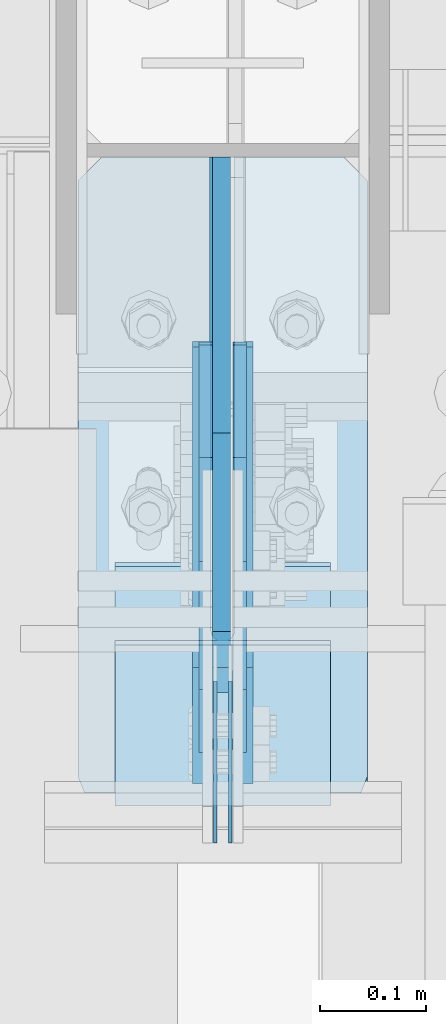
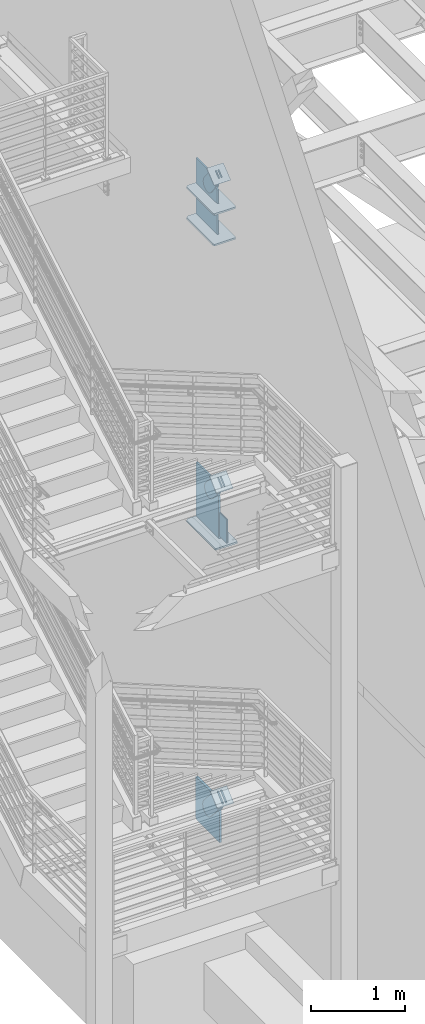
# One storey, part 1058 of 1179: 17 plates, 11 elements without a shape of their own.
"""IFC2X3 building model written with IfcOpenShell, lengths in millimetres."""

from ifc_helpers import new_model, si_unit, frame, origin_with_axes, place, context, subcontext, project, spatial, faceted_brep, material, type_object, element, aggregate, save


model = new_model("IFC2X3")

# Units and contexts
model_context = context("Model", 3, precision=1e-05, world=origin_with_axes())
body_context = subcontext(model_context, "Body", "Model", "MODEL_VIEW")
ifc_project = project(units=[si_unit("LENGTHUNIT", "METRE", prefix="MILLI"), si_unit("AREAUNIT", "SQUARE_METRE"), si_unit("VOLUMEUNIT", "CUBIC_METRE"), si_unit("MASSUNIT", "GRAM", prefix="KILO"), si_unit("TIMEUNIT", "SECOND"), si_unit("PLANEANGLEUNIT", "RADIAN"), si_unit("SOLIDANGLEUNIT", "STERADIAN"), si_unit("THERMODYNAMICTEMPERATUREUNIT", "DEGREE_CELSIUS"), si_unit("LUMINOUSINTENSITYUNIT", "LUMEN")], contexts=[model_context])

# Site, building, storey
site_placement = place(None, origin_with_axes())
site = spatial("IfcSite", under=ifc_project, at=site_placement, CompositionType="ELEMENT")
building_placement = place(site_placement, origin_with_axes())
building = spatial("IfcBuilding", under=site, at=building_placement, Name="Undefined", CompositionType="ELEMENT")
storey_placement = place(building_placement, origin_with_axes())
storey = spatial("IfcBuildingStorey", under=building, at=storey_placement, Name="Undefined", CompositionType="ELEMENT", Elevation=0.0)

# Assembly, plates
assembly_1_placement = place(storey_placement, origin_with_axes())
assembly_1 = element("IfcElementAssembly", 1, at=assembly_1_placement, inside=storey, Name="COLUMN", AssemblyPlace="NOTDEFINED", PredefinedType="RIGID_FRAME")
ifc_material_1 = material(Name="STEEL/A572-GR.50")
plate_type_1 = type_object("IfcPlateType", PredefinedType="NOTDEFINED")
plate_1_placement = place(assembly_1_placement, frame((295.274993912948, 33785.7907939296, 7605.7125), z_axis=(0.0, 1.0, 0.0), x_axis=(1.0, 0.0, 0.0)))
plate_1 = element("IfcPlate", 2, at=plate_1_placement, type_object=plate_type_1, material=ifc_material_1, Name="PLATE", context=body_context, shape_type="Brep", body=[
    faceted_brep([(125.412506087054, -11.1125000000002, 599.459206069892), (125.412487792968, -11.1125000000002, 153.987500190735), (125.412487792968, 11.1125000000002, 153.987500190735), (125.412506087054, 11.1125000000002, 599.459206069892), (126.258376502454, -11.1125000000002, 149.734930475586), (126.258376502454, 11.1125000000002, 149.734930475586), (128.667263742896, -11.1125000000002, 146.12977594993), (128.667263742896, 11.1125000000002, 146.12977594993), (132.272418268556, -11.1125000000002, 143.720888709488), (132.272418268556, 11.1125000000002, 143.720888709488), (136.524987602239, -11.1125000000002, 142.875), (136.524987602239, 11.1125000000002, 142.875), (140.777557317386, -11.1125000000002, 143.720888709488), (140.777557317386, 11.1125000000002, 143.720888709488), (144.382711843045, -11.1125000000002, 146.12977594993), (144.382711843045, 11.1125000000002, 146.12977594993), (146.791599083488, -11.1125000000002, 149.734930475586), (146.791599083488, 11.1125000000002, 149.734930475586), (147.637487792974, -11.1125000000002, 153.987500190735), (147.637487792974, 11.1125000000002, 153.987500190735), (147.637506087054, -11.1125000000002, 599.459206070445), (147.637506087054, 11.1125000000002, 599.4592060699), (-2.34018671108061e-09, -11.1125000000002, 577.234205688423), (22.2250003790394, -11.1125000000002, 599.459206069892), (22.2250003790394, 11.1125000000002, 599.459206069892), (-2.34018671108061e-09, 11.1125000000002, 577.234205688423), (0.0, -11.1125000000002, 15.875), (0.0, 11.1125000000002, 15.875), (6.34999990463257, -11.1125000000002, 0.0), (6.34999990463257, 11.1125000000002, 0.0), (266.699987888336, -11.1125000000002, 0.0), (266.699987888336, 11.1125000000002, 0.0), (273.049987792969, -11.1125000000002, 15.875), (273.049987792969, 11.1125000000002, 15.875), (273.050006084718, -11.1125000000002, 577.23420568843), (273.050006084718, 11.1125000000002, 577.23420568843), (250.825005703158, -11.1125000000002, 599.4592060699), (250.825005703158, 11.1125000000002, 599.4592060699)], [[[0, 1, 2, 3]], [[4, 5, 2, 1]], [[6, 7, 5, 4]], [[8, 9, 7, 6]], [[10, 11, 9, 8]], [[12, 13, 11, 10]], [[14, 15, 13, 12]], [[16, 17, 15, 14]], [[18, 19, 17, 16]], [[20, 21, 19, 18]], [[22, 23, 24, 25]], [[26, 22, 25, 27]], [[28, 26, 27, 29]], [[30, 28, 29, 31]], [[32, 30, 31, 33]], [[34, 32, 33, 35]], [[36, 34, 35, 37]], [[16, 14, 12, 10, 8, 6, 4, 1, 0, 23, 22, 26, 28, 30, 32, 34, 36, 20, 18]], [[24, 23, 0, 3]], [[37, 35, 33, 31, 29, 27, 25, 24, 3, 2, 5, 7, 9, 11, 13, 15, 17, 19, 21]], [[36, 37, 21, 20]]]),
])
plate_2_placement = place(assembly_1_placement, frame((295.274993912948, 33785.7907939296, 8002.5875), z_axis=(0.0, 1.0, 0.0), x_axis=(1.0, 0.0, 0.0)))
plate_2 = element("IfcPlate", 3, at=plate_2_placement, type_object=plate_type_1, material=ifc_material_1, Name="PLATE", context=body_context, shape_type="Brep", body=[
    faceted_brep([(125.412506087054, -11.1125000000002, 599.459206069892), (125.412487792968, -11.1125000000002, 153.987500190735), (125.412487792968, 11.1125000000002, 153.987500190735), (125.412506087054, 11.1125000000002, 599.459206069892), (126.258376502454, -11.1125000000002, 149.734930475586), (126.258376502454, 11.1125000000002, 149.734930475586), (128.667263742896, -11.1125000000002, 146.12977594993), (128.667263742896, 11.1125000000002, 146.12977594993), (132.272418268556, -11.1125000000002, 143.720888709488), (132.272418268556, 11.1125000000002, 143.720888709488), (136.524987602239, -11.1125000000002, 142.875), (136.524987602239, 11.1125000000002, 142.875), (140.777557317386, -11.1125000000002, 143.720888709488), (140.777557317386, 11.1125000000002, 143.720888709488), (144.382711843045, -11.1125000000002, 146.12977594993), (144.382711843045, 11.1125000000002, 146.12977594993), (146.791599083488, -11.1125000000002, 149.734930475586), (146.791599083488, 11.1125000000002, 149.734930475586), (147.637487792974, -11.1125000000002, 153.987500190735), (147.637487792974, 11.1125000000002, 153.987500190735), (147.637506087054, -11.1125000000002, 599.459206070445), (147.637506087054, 11.1125000000002, 599.4592060699), (-2.34018671108061e-09, -11.1125000000002, 577.234205688423), (22.2250003790394, -11.1125000000002, 599.459206069892), (22.2250003790394, 11.1125000000002, 599.459206069892), (-2.34018671108061e-09, 11.1125000000002, 577.234205688423), (0.0, -11.1125000000002, 15.875), (0.0, 11.1125000000002, 15.875), (6.34999990463257, -11.1125000000002, 0.0), (6.34999990463257, 11.1125000000002, 0.0), (266.699987888336, -11.1125000000002, 0.0), (266.699987888336, 11.1125000000002, 0.0), (273.049987792969, -11.1125000000002, 15.875), (273.049987792969, 11.1125000000002, 15.875), (273.050006084718, -11.1125000000002, 577.23420568843), (273.050006084718, 11.1125000000002, 577.23420568843), (250.825005703158, -11.1125000000002, 599.4592060699), (250.825005703158, 11.1125000000002, 599.4592060699)], [[[0, 1, 2, 3]], [[4, 5, 2, 1]], [[6, 7, 5, 4]], [[8, 9, 7, 6]], [[10, 11, 9, 8]], [[12, 13, 11, 10]], [[14, 15, 13, 12]], [[16, 17, 15, 14]], [[18, 19, 17, 16]], [[20, 21, 19, 18]], [[22, 23, 24, 25]], [[26, 22, 25, 27]], [[28, 26, 27, 29]], [[30, 28, 29, 31]], [[32, 30, 31, 33]], [[34, 32, 33, 35]], [[36, 34, 35, 37]], [[16, 14, 12, 10, 8, 6, 4, 1, 0, 23, 22, 26, 28, 30, 32, 34, 36, 20, 18]], [[24, 23, 0, 3]], [[37, 35, 33, 31, 29, 27, 25, 24, 3, 2, 5, 7, 9, 11, 13, 15, 17, 19, 21]], [[36, 37, 21, 20]]]),
])
plate_3_placement = place(assembly_1_placement, frame((295.275012207031, 33751.616998869, 3694.1125), z_axis=(0.0, 1.0, 0.0), x_axis=(1.0, 0.0, 0.0)))
plate_3 = element("IfcPlate", 4, at=plate_3_placement, type_object=plate_type_1, material=ifc_material_1, Name="PLATE", context=body_context, shape_type="Brep", body=[
    faceted_brep([(125.412487792972, -11.1125000000002, 633.633001130984), (125.412487792968, -11.1125000000002, 153.987500190735), (125.412487792968, 11.1125000000002, 153.987500190735), (125.412487792972, 11.1125000000002, 633.633001130984), (126.258376502454, -11.1125000000002, 149.734930475586), (126.258376502454, 11.1125000000002, 149.734930475586), (128.667263742896, -11.1125000000002, 146.12977594993), (128.667263742896, 11.1125000000002, 146.12977594993), (132.272418268556, -11.1125000000002, 143.720888709488), (132.272418268556, 11.1125000000002, 143.720888709488), (136.524987602239, -11.1125000000002, 142.875), (136.524987602239, 11.1125000000002, 142.875), (140.777557317386, -11.1125000000002, 143.720888709488), (140.777557317386, 11.1125000000002, 143.720888709488), (144.382711843045, -11.1125000000002, 146.12977594993), (144.382711843045, 11.1125000000002, 146.12977594993), (146.791599083488, -11.1125000000002, 149.734930475586), (146.791599083488, 11.1125000000002, 149.734930475586), (147.637487792974, -11.1125000000002, 153.987500190735), (147.637487792974, 11.1125000000002, 153.987500190735), (147.637487792977, -11.1125000000002, 633.633001130984), (147.637487792977, 11.1125000000002, 633.633001130984), (0.0, -11.1125000000002, 611.408000749514), (22.2250003814697, -11.1125000000002, 633.633001130984), (22.2250003814697, 11.1125000000002, 633.633001130984), (0.0, 11.1125000000002, 611.408000749514), (0.0, -11.1125000000002, 15.875), (0.0, 11.1125000000002, 15.875), (6.34999990463257, -11.1125000000002, 0.0), (6.34999990463257, 11.1125000000002, 0.0), (266.699987888336, -11.1125000000002, 0.0), (266.699987888336, 11.1125000000002, 0.0), (273.049987792969, -11.1125000000002, 15.875), (273.049987792969, 11.1125000000002, 15.875), (273.049987792969, -11.1125000000002, 611.408000749514), (273.049987792969, 11.1125000000002, 611.408000749514), (250.824987411499, -11.1125000000002, 633.633001130984), (250.824987411499, 11.1125000000002, 633.633001130984)], [[[0, 1, 2, 3]], [[4, 5, 2, 1]], [[6, 7, 5, 4]], [[8, 9, 7, 6]], [[10, 11, 9, 8]], [[12, 13, 11, 10]], [[14, 15, 13, 12]], [[16, 17, 15, 14]], [[18, 19, 17, 16]], [[20, 21, 19, 18]], [[22, 23, 24, 25]], [[26, 22, 25, 27]], [[28, 26, 27, 29]], [[30, 28, 29, 31]], [[32, 30, 31, 33]], [[34, 32, 33, 35]], [[36, 34, 35, 37]], [[16, 14, 12, 10, 8, 6, 4, 1, 0, 23, 22, 26, 28, 30, 32, 34, 36, 20, 18]], [[24, 23, 0, 3]], [[37, 35, 33, 31, 29, 27, 25, 24, 3, 2, 5, 7, 9, 11, 13, 15, 17, 19, 21]], [[36, 37, 21, 20]]]),
])

# Assembly, plate
assembly_2_placement = place(storey_placement, origin_with_axes())
assembly_2 = element("IfcElementAssembly", 5, at=assembly_2_placement, inside=storey, AssemblyPlace="NOTDEFINED", PredefinedType="RIGID_FRAME")
ifc_material_2 = material(Name="STEEL/A36")
plate_type_2 = type_object("IfcPlateType", PredefinedType="NOTDEFINED")
plate_4_placement = place(assembly_2_placement, frame((415.925000000002, 33955.4291271729, 8429.10014124808), z_axis=(0.0, -0.784152810390105, -0.620567780308727), x_axis=(0.0, 0.620567780308723, -0.784152810390108)))
plate_4 = element("IfcPlate", 6, at=plate_4_placement, type_object=plate_type_2, material=ifc_material_2, context=body_context, shape_type="Brep", body=[
    faceted_brep([(0.0, -6.34999999999854, 0.0), (-8.18545231595635e-11, -6.34999999999854, 91.5986124346418), (-8.18545231595635e-11, 6.34999999999854, 91.5986124346418), (0.0, 6.34999999999854, 0.0), (78.1049999999705, -6.35000000000002, 91.5986124333795), (78.1049999999705, 6.35000000000002, 91.5986124333795), (179.705000000962, -6.35000000000002, 136.286806215146), (179.705000000962, 6.35000000000002, 136.286806215146), (324.789985849511, -6.35000000000002, 136.286806214965), (324.789985849511, 6.35000000000002, 136.286806214965), (359.418054103589, -6.35000000000002, 129.39885518072), (359.418054103589, 6.35000000000002, 129.39885518072), (388.774312870144, -6.35000000000002, 109.783630183585), (388.774312870144, 6.35000000000002, 109.783630183585), (408.389537867102, -6.35000000000002, 80.4273714169249), (408.389537867102, 6.35000000000002, 80.4273714169249), (415.277488901111, -6.35000000000002, 45.7993092689831), (415.277488901111, 6.35000000000002, 45.7993092689831), (408.389537866744, -6.35000000000002, 11.1712410151376), (408.389537866744, 6.35000000000002, 11.1712410151376), (388.774312869609, -6.35000000000002, -18.1850177512206), (388.774312869609, 6.35000000000002, -18.1850177512206), (359.418054103053, -6.35000000000002, -37.8002427481115), (359.418054103053, 6.35000000000002, -37.8002427481115), (324.7899888999, -6.35000000000002, -44.6881937822109), (324.7899888999, 6.35000000000002, -44.6881937822109), (179.704999999849, -6.35000000000002, -44.6881937820726), (179.704999999849, 6.35000000000002, -44.6881937820726), (78.1049999994066, -6.35000000000002, -1.0550138540566e-10), (78.1049999994066, 6.35000000000002, -1.0550138540566e-10)], [[[0, 1, 2, 3]], [[1, 4, 5, 2]], [[4, 6, 7, 5]], [[6, 8, 9, 7]], [[8, 10, 11, 9]], [[10, 12, 13, 11]], [[12, 14, 15, 13]], [[14, 16, 17, 15]], [[16, 18, 19, 17]], [[18, 20, 21, 19]], [[20, 22, 23, 21]], [[22, 24, 25, 23]], [[24, 26, 27, 25]], [[26, 28, 29, 27]], [[28, 0, 3, 29]], [[5, 7, 9, 11, 13, 15, 17, 19, 21, 23, 25, 27, 29, 3, 2]], [[28, 26, 24, 22, 20, 18, 16, 14, 12, 10, 8, 6, 4, 1, 0]]]),
])
aggregate(assembly_2, [plate_4])

assembly_3_placement = place(storey_placement, origin_with_axes())
assembly_3 = element("IfcElementAssembly", 7, at=assembly_3_placement, inside=storey, AssemblyPlace="NOTDEFINED", PredefinedType="RIGID_FRAME")
plate_5_placement = place(assembly_3_placement, frame((447.675000000002, 33955.4291271729, 8429.10014124808), z_axis=(0.0, -0.784152810390105, -0.620567780308727), x_axis=(0.0, 0.620567780308723, -0.784152810390108)))
plate_5 = element("IfcPlate", 8, at=plate_5_placement, type_object=plate_type_2, material=ifc_material_2, context=body_context, shape_type="Brep", body=[
    faceted_brep([(0.0, -6.34999999999854, 0.0), (-8.18545231595635e-11, -6.34999999999854, 91.5986124346418), (-8.18545231595635e-11, 6.34999999999854, 91.5986124346418), (0.0, 6.34999999999854, 0.0), (78.1049999999705, -6.35000000000002, 91.5986124333795), (78.1049999999705, 6.35000000000002, 91.5986124333795), (179.705000000962, -6.35000000000002, 136.286806215146), (179.705000000962, 6.35000000000002, 136.286806215146), (324.789985849511, -6.35000000000002, 136.286806214965), (324.789985849511, 6.35000000000002, 136.286806214965), (359.418054103589, -6.35000000000002, 129.39885518072), (359.418054103589, 6.35000000000002, 129.39885518072), (388.774312870144, -6.35000000000002, 109.783630183585), (388.774312870144, 6.35000000000002, 109.783630183585), (408.389537867102, -6.35000000000002, 80.4273714169249), (408.389537867102, 6.35000000000002, 80.4273714169249), (415.277488901111, -6.35000000000002, 45.7993092689831), (415.277488901111, 6.35000000000002, 45.7993092689831), (408.389537866744, -6.35000000000002, 11.1712410151376), (408.389537866744, 6.35000000000002, 11.1712410151376), (388.774312869609, -6.35000000000002, -18.1850177512206), (388.774312869609, 6.35000000000002, -18.1850177512206), (359.418054103053, -6.35000000000002, -37.8002427481115), (359.418054103053, 6.35000000000002, -37.8002427481115), (324.7899888999, -6.35000000000002, -44.6881937822109), (324.7899888999, 6.35000000000002, -44.6881937822109), (179.704999999849, -6.35000000000002, -44.6881937820726), (179.704999999849, 6.35000000000002, -44.6881937820726), (78.1049999994066, -6.35000000000002, -1.0550138540566e-10), (78.1049999994066, 6.35000000000002, -1.0550138540566e-10)], [[[0, 1, 2, 3]], [[1, 4, 5, 2]], [[4, 6, 7, 5]], [[6, 8, 9, 7]], [[8, 10, 11, 9]], [[10, 12, 13, 11]], [[12, 14, 15, 13]], [[14, 16, 17, 15]], [[16, 18, 19, 17]], [[18, 20, 21, 19]], [[20, 22, 23, 21]], [[22, 24, 25, 23]], [[24, 26, 27, 25]], [[26, 28, 29, 27]], [[28, 0, 3, 29]], [[5, 7, 9, 11, 13, 15, 17, 19, 21, 23, 25, 27, 29, 3, 2]], [[28, 26, 24, 22, 20, 18, 16, 14, 12, 10, 8, 6, 4, 1, 0]]]),
])
aggregate(assembly_3, [plate_5])

assembly_4_placement = place(storey_placement, origin_with_axes())
assembly_4 = element("IfcElementAssembly", 9, at=assembly_4_placement, inside=storey, Name="Plate", AssemblyPlace="NOTDEFINED", PredefinedType="RIGID_FRAME")
plate_type_3 = type_object("IfcPlateType", PredefinedType="NOTDEFINED")
plate_6_placement = place(assembly_4_placement, frame((330.200000000002, 33841.8158496579, 8335.13919579797), z_axis=(0.0, 0.784152810390107, 0.620567780308724), x_axis=(1.0, 0.0, 0.0)))
plate_6 = element("IfcPlate", 10, at=plate_6_placement, type_object=plate_type_3, material=ifc_material_2, Name="Plate", context=body_context, shape_type="Brep", body=[
    faceted_brep([(0.0, -3.17500000000109, 0.0), (0.0, -3.17500000000291, 203.200000000368), (0.0, 3.17499999998836, 203.200000000361), (0.0, 3.17500000000109, 7.27595761418343e-12), (203.199999999997, -3.17500000000291, 203.200000000368), (203.199999999997, 3.17499999998836, 203.200000000361), (203.199999999997, -3.17499999999927, 3.63797880709171e-12), (203.199999999997, 3.17499999999382, -3.63797880709171e-12)], [[[0, 1, 2, 3]], [[1, 4, 5, 2]], [[4, 6, 7, 5]], [[6, 0, 3, 7]], [[5, 7, 3, 2]], [[6, 4, 1, 0]]]),
])
aggregate(assembly_4, [plate_6])

assembly_5_placement = place(storey_placement, origin_with_axes())
assembly_5 = element("IfcElementAssembly", 11, at=assembly_5_placement, inside=storey, Name="Plate", AssemblyPlace="NOTDEFINED", PredefinedType="RIGID_FRAME")
plate_7_placement = place(assembly_5_placement, frame((330.200000000002, 33792.9181363672, 4382.10915283132), z_axis=(0.0, 0.729241792887681, 0.684256097894612), x_axis=(1.0, 0.0, 0.0)))
plate_7 = element("IfcPlate", 12, at=plate_7_placement, type_object=plate_type_3, material=ifc_material_2, Name="Plate", context=body_context, shape_type="Brep", body=[
    faceted_brep([(0.0, -3.17500000000109, 0.0), (0.0, -3.17500000000291, 203.200000000368), (0.0, 3.17499999998836, 203.200000000361), (0.0, 3.17500000000109, 7.27595761418343e-12), (203.199999999997, -3.17500000000291, 203.200000000368), (203.199999999997, 3.17499999998836, 203.200000000361), (203.199999999997, -3.17499999999927, 3.63797880709171e-12), (203.199999999997, 3.17499999999382, -3.63797880709171e-12)], [[[0, 1, 2, 3]], [[1, 4, 5, 2]], [[4, 6, 7, 5]], [[6, 0, 3, 7]], [[5, 7, 3, 2]], [[6, 4, 1, 0]]]),
])
aggregate(assembly_5, [plate_7])

assembly_6_placement = place(storey_placement, origin_with_axes())
assembly_6 = element("IfcElementAssembly", 13, at=assembly_6_placement, inside=storey, Name="Plate", AssemblyPlace="NOTDEFINED", PredefinedType="RIGID_FRAME")
plate_8_placement = place(assembly_6_placement, frame((330.200000000002, 33775.8094640308, 320.900121116472), z_axis=(0.0, 0.745753571678113, 0.666221892712434), x_axis=(1.0, 0.0, 0.0)))
plate_8 = element("IfcPlate", 14, at=plate_8_placement, type_object=plate_type_3, material=ifc_material_2, Name="Plate", context=body_context, shape_type="Brep", body=[
    faceted_brep([(0.0, -3.17500000000109, 0.0), (0.0, -3.17500000000291, 203.200000000368), (0.0, 3.17499999998836, 203.200000000361), (0.0, 3.17500000000109, 7.27595761418343e-12), (203.199999999997, -3.17500000000291, 203.200000000368), (203.199999999997, 3.17499999998836, 203.200000000361), (203.199999999997, -3.17499999999927, 3.63797880709171e-12), (203.199999999997, 3.17499999999382, -3.63797880709171e-12)], [[[0, 1, 2, 3]], [[1, 4, 5, 2]], [[4, 6, 7, 5]], [[6, 0, 3, 7]], [[5, 7, 3, 2]], [[6, 4, 1, 0]]]),
])
aggregate(assembly_6, [plate_8])

# Assembly, plates
assembly_7_placement = place(storey_placement, origin_with_axes())
assembly_7 = element("IfcElementAssembly", 15, at=assembly_7_placement, inside=storey, Name="BEAM", AssemblyPlace="NOTDEFINED", PredefinedType="RIGID_FRAME")
plate_type_4 = type_object("IfcPlateType", PredefinedType="NOTDEFINED")
plate_9_placement = place(assembly_7_placement, frame((438.943750000002, 33891.316998869, 4044.95), z_axis=(0.0, 0.0, -1.0), x_axis=(0.0, -1.0, 0.0)))
plate_9 = element("IfcPlate", 16, at=plate_9_placement, type_object=plate_type_4, material=ifc_material_1, Name="PLATE", context=body_context, shape_type="Brep", body=[
    faceted_brep([(3.63797880709171e-12, -1.58750000000055, 1.81898940354586e-12), (-2.18278728425503e-11, -1.58750000000146, 304.8), (-2.18278728425503e-11, 1.58750000000146, 304.8), (-3.63797880709171e-12, 1.58750000000055, 0.0), (152.399999999994, -1.58750000000146, 304.8), (152.399999999994, 1.58750000000146, 304.8), (152.399999999994, -1.58750000000146, 0.0), (152.399999999994, 1.58750000000146, 0.0)], [[[0, 1, 2, 3]], [[1, 4, 5, 2]], [[4, 6, 7, 5]], [[6, 0, 3, 7]], [[5, 7, 3, 2]], [[6, 4, 1, 0]]]),
])
plate_10_placement = place(assembly_7_placement, frame((424.656250000002, 33891.316998869, 4044.95), z_axis=(0.0, 0.0, -1.0), x_axis=(0.0, -1.0, 0.0)))
plate_10 = element("IfcPlate", 17, at=plate_10_placement, type_object=plate_type_4, material=ifc_material_1, Name="PLATE", context=body_context, shape_type="Brep", body=[
    faceted_brep([(3.63797880709171e-12, -1.58750000000055, 1.81898940354586e-12), (-2.18278728425503e-11, -1.58750000000146, 304.8), (-2.18278728425503e-11, 1.58750000000146, 304.8), (-3.63797880709171e-12, 1.58750000000055, 0.0), (152.399999999994, -1.58750000000146, 304.8), (152.399999999994, 1.58750000000146, 304.8), (152.399999999994, -1.58750000000146, 0.0), (152.399999999994, 1.58750000000146, 0.0)], [[[0, 1, 2, 3]], [[1, 4, 5, 2]], [[4, 6, 7, 5]], [[6, 0, 3, 7]], [[5, 7, 3, 2]], [[6, 4, 1, 0]]]),
])
aggregate(assembly_7, [plate_9, plate_10])

# Assembly, plate
assembly_8_placement = place(storey_placement, origin_with_axes())
assembly_8 = element("IfcElementAssembly", 18, at=assembly_8_placement, inside=storey, AssemblyPlace="NOTDEFINED", PredefinedType="RIGID_FRAME")
plate_type_5 = type_object("IfcPlateType", PredefinedType="NOTDEFINED")
plate_11_placement = place(assembly_8_placement, frame((415.925000000002, 33905.74155945, 4492.32652657097), z_axis=(0.0, -0.729241792887679, -0.684256097894614), x_axis=(0.0, 0.684256097894613, -0.72924179288768)))
plate_11 = element("IfcPlate", 19, at=plate_11_placement, type_object=plate_type_5, material=ifc_material_2, context=body_context, shape_type="Brep", body=[
    faceted_brep([(0.0, -6.34999999999854, 0.0), (-4.35647962149233e-10, -6.34999999999854, 112.184930806416), (-4.35647962149233e-10, 6.34999999999854, 112.184930806416), (0.0, 6.34999999999854, 0.0), (82.5499999996491, -6.34999999999854, 112.184930806461), (82.5499999996491, 6.34999999999854, 112.184930806461), (184.149999999618, -6.34999999999854, 149.75496540347), (184.149999999618, 6.34999999999854, 149.75496540347), (327.919242323534, -6.34999999999854, 149.754965403559), (327.919242323534, 6.34999999999854, 149.754965403559), (363.762328723451, -6.34999999999854, 142.625332233587), (363.762328723451, 6.34999999999854, 142.625332233587), (394.148630137406, -6.34999999999854, 122.321854743475), (394.148630137406, 6.34999999999854, 122.321854743475), (414.452107627645, -6.34999999999854, 91.9355533295929), (414.452107627645, 6.34999999999854, 91.9355533295929), (421.581740797776, -6.34999999999854, 56.0924638777396), (421.581740797776, 6.34999999999854, 56.0924638777396), (414.452107627878, -6.34999999999854, 20.2493774776722), (414.452107627878, 6.34999999999854, 20.2493774776722), (394.14863013775, -6.34999999999854, -10.1369239363994), (394.14863013775, 6.34999999999854, -10.1369239363994), (363.762328723789, -6.34999999999854, -30.4404014266784), (363.762328723789, 6.34999999999854, -30.4404014266784), (327.919240798041, -6.34999999999854, -37.570034596738), (327.919240798041, 6.34999999999854, -37.570034596738), (184.150000000338, -6.34999999999854, -37.5700345968289), (184.150000000338, 6.34999999999854, -37.5700345968289), (82.550000000203, -6.34999999999854, 1.2732925824821e-10), (82.550000000203, 6.34999999999854, 1.2732925824821e-10)], [[[0, 1, 2, 3]], [[1, 4, 5, 2]], [[4, 6, 7, 5]], [[6, 8, 9, 7]], [[8, 10, 11, 9]], [[10, 12, 13, 11]], [[12, 14, 15, 13]], [[14, 16, 17, 15]], [[16, 18, 19, 17]], [[18, 20, 21, 19]], [[20, 22, 23, 21]], [[22, 24, 25, 23]], [[24, 26, 27, 25]], [[26, 28, 29, 27]], [[28, 0, 3, 29]], [[5, 7, 9, 11, 13, 15, 17, 19, 21, 23, 25, 27, 29, 3, 2]], [[28, 26, 24, 22, 20, 18, 16, 14, 12, 10, 8, 6, 4, 1, 0]]]),
])
aggregate(assembly_8, [plate_11])

assembly_9_placement = place(storey_placement, origin_with_axes())
assembly_9 = element("IfcElementAssembly", 20, at=assembly_9_placement, inside=storey, AssemblyPlace="NOTDEFINED", PredefinedType="RIGID_FRAME")
plate_12_placement = place(assembly_9_placement, frame((447.675000000002, 33905.74155945, 4492.32652657097), z_axis=(0.0, -0.729241792887679, -0.684256097894614), x_axis=(0.0, 0.684256097894613, -0.72924179288768)))
plate_12 = element("IfcPlate", 21, at=plate_12_placement, type_object=plate_type_5, material=ifc_material_2, context=body_context, shape_type="Brep", body=[
    faceted_brep([(0.0, -6.34999999999854, 0.0), (-4.35647962149233e-10, -6.34999999999854, 112.184930806416), (-4.35647962149233e-10, 6.34999999999854, 112.184930806416), (0.0, 6.34999999999854, 0.0), (82.5499999996491, -6.34999999999854, 112.184930806461), (82.5499999996491, 6.34999999999854, 112.184930806461), (184.149999999618, -6.34999999999854, 149.75496540347), (184.149999999618, 6.34999999999854, 149.75496540347), (327.919242323534, -6.34999999999854, 149.754965403559), (327.919242323534, 6.34999999999854, 149.754965403559), (363.762328723451, -6.34999999999854, 142.625332233587), (363.762328723451, 6.34999999999854, 142.625332233587), (394.148630137406, -6.34999999999854, 122.321854743475), (394.148630137406, 6.34999999999854, 122.321854743475), (414.452107627645, -6.34999999999854, 91.9355533295929), (414.452107627645, 6.34999999999854, 91.9355533295929), (421.581740797776, -6.34999999999854, 56.0924638777396), (421.581740797776, 6.34999999999854, 56.0924638777396), (414.452107627878, -6.34999999999854, 20.2493774776722), (414.452107627878, 6.34999999999854, 20.2493774776722), (394.14863013775, -6.34999999999854, -10.1369239363994), (394.14863013775, 6.34999999999854, -10.1369239363994), (363.762328723789, -6.34999999999854, -30.4404014266784), (363.762328723789, 6.34999999999854, -30.4404014266784), (327.919240798041, -6.34999999999854, -37.570034596738), (327.919240798041, 6.34999999999854, -37.570034596738), (184.150000000338, -6.34999999999854, -37.5700345968289), (184.150000000338, 6.34999999999854, -37.5700345968289), (82.550000000203, -6.34999999999854, 1.2732925824821e-10), (82.550000000203, 6.34999999999854, 1.2732925824821e-10)], [[[0, 1, 2, 3]], [[1, 4, 5, 2]], [[4, 6, 7, 5]], [[6, 8, 9, 7]], [[8, 10, 11, 9]], [[10, 12, 13, 11]], [[12, 14, 15, 13]], [[14, 16, 17, 15]], [[16, 18, 19, 17]], [[18, 20, 21, 19]], [[20, 22, 23, 21]], [[22, 24, 25, 23]], [[24, 26, 27, 25]], [[26, 28, 29, 27]], [[28, 0, 3, 29]], [[5, 7, 9, 11, 13, 15, 17, 19, 21, 23, 25, 27, 29, 3, 2]], [[28, 26, 24, 22, 20, 18, 16, 14, 12, 10, 8, 6, 4, 1, 0]]]),
])
aggregate(assembly_9, [plate_12])

# Plate
plate_type_6 = type_object("IfcPlateType", PredefinedType="NOTDEFINED")
plate_13_placement = place(assembly_1_placement, frame((431.800000000002, 34385.25, 7575.55), z_axis=(0.0, 0.0, 1.0), x_axis=(0.0, -1.0, 0.0)))
plate_13 = element("IfcPlate", 22, at=plate_13_placement, type_object=plate_type_6, material=ifc_material_1, Name="PLATE", context=body_context, shape_type="Brep", body=[
    faceted_brep([(0.0, -9.52499999999964, 0.0), (0.0, -9.52499999999998, 758.618120470426), (0.0, 9.52499999999998, 758.618120470426), (0.0, 9.52499999999964, 0.0), (260.195906062254, -9.52499999999998, 758.618120470426), (260.195906062254, 9.52499999999998, 758.618120470426), (447.059206070444, -9.52499999999998, 610.737067478271), (447.059206070444, 9.52499999999998, 610.737067478271), (447.059206070444, -9.52499999999998, 0.0), (447.059206070444, 9.52499999999998, 0.0)], [[[0, 1, 2, 3]], [[1, 4, 5, 2]], [[4, 6, 7, 5]], [[6, 8, 9, 7]], [[8, 0, 3, 9]], [[5, 7, 9, 3, 2]], [[8, 6, 4, 1, 0]]]),
])

plate_type_7 = type_object("IfcPlateType", PredefinedType="NOTDEFINED")
plate_14_placement = place(assembly_1_placement, frame((431.800000000002, 34385.25, 3663.95), z_axis=(0.0, 0.0, 1.0), x_axis=(0.0, -1.0, 0.0)))
plate_14 = element("IfcPlate", 23, at=plate_14_placement, type_object=plate_type_7, material=ifc_material_1, Name="PLATE", context=body_context, shape_type="Brep", body=[
    faceted_brep([(0.0, -9.52499999999964, 0.0), (0.0, -9.52499999999998, 737.174280571875), (0.0, 9.52499999999998, 737.174280571875), (0.0, 9.52499999999964, 0.0), (307.582299199603, -9.52499999999998, 737.174280571875), (307.582299199603, 9.52499999999998, 737.174280571875), (481.233001130982, -9.52499999999998, 574.235797260721), (481.233001130982, 9.52499999999998, 574.235797260721), (481.233001130982, -9.52499999999998, 0.0), (481.233001130982, 9.52499999999998, 0.0)], [[[0, 1, 2, 3]], [[1, 4, 5, 2]], [[4, 6, 7, 5]], [[6, 8, 9, 7]], [[8, 0, 3, 9]], [[5, 7, 9, 3, 2]], [[8, 6, 4, 1, 0]]]),
])

plate_type_8 = type_object("IfcPlateType", PredefinedType="NOTDEFINED")
plate_15_placement = place(assembly_1_placement, frame((431.8, 34385.25, -215.9), z_axis=(0.0, 0.0, 1.0), x_axis=(0.0, -1.0, 0.0)))
plate_15 = element("IfcPlate", 24, at=plate_15_placement, type_object=plate_type_8, material=ifc_material_1, Name="PLATE", context=body_context, shape_type="Brep", body=[
    faceted_brep([(0.0, -12.7000000000007, 19.0500000000029), (0.0, -12.7, 551.799398203347), (0.0, 12.7, 551.799398203347), (0.0, 12.7000000000007, 19.0500000000029), (324.819501230952, -12.7, 551.799398203347), (324.819501230952, 12.7, 551.799398203347), (504.769838076878, -12.7, 391.040055491836), (504.769838076878, 12.7, 391.040055491836), (504.769838076878, -12.7, 0.0), (504.769838076878, 12.7, 0.0), (19.0499992370605, -12.6999999999971, 0.0), (19.0499992370605, 12.6999999999971, 0.0)], [[[0, 1, 2, 3]], [[1, 4, 5, 2]], [[4, 6, 7, 5]], [[6, 8, 9, 7]], [[8, 10, 11, 9]], [[10, 0, 3, 11]], [[5, 7, 9, 11, 3, 2]], [[10, 8, 6, 4, 1, 0]]]),
])

aggregate(assembly_1, [plate_1, plate_2, plate_13, plate_14, plate_15, plate_3])

# Assembly, plate
assembly_10_placement = place(storey_placement, origin_with_axes())
assembly_10 = element("IfcElementAssembly", 25, at=assembly_10_placement, inside=storey, AssemblyPlace="NOTDEFINED", PredefinedType="RIGID_FRAME")
plate_type_9 = type_object("IfcPlateType", PredefinedType="NOTDEFINED")
plate_16_placement = place(assembly_10_placement, frame((411.162500000002, 33904.240177085, 439.891643383348), z_axis=(0.0, -0.74575357167811, -0.666221892712438), x_axis=(0.0, 0.666221892712438, -0.74575357167811)))
plate_16 = element("IfcPlate", 26, at=plate_16_placement, type_object=plate_type_9, material=ifc_material_2, context=body_context, shape_type="Brep", body=[
    faceted_brep([(0.0, -7.9375, 0.0), (-8.00355337560177e-11, -7.9375, 146.904840309817), (-8.00355337560177e-11, 7.9375, 146.904840309817), (0.0, 7.9375, 0.0), (80.0100000003295, -7.9375, 146.904840309766), (80.0100000003295, 7.9375, 146.904840309766), (181.610000002391, -7.9375, 168.702420152473), (181.610000002391, 7.9375, 168.702420152473), (400.931138856435, -7.9375, 168.702420152254), (400.931138856435, 7.9375, 168.702420152254), (437.38173578924, -7.9375, 161.451945623954), (437.38173578924, 7.9375, 161.451945623954), (468.283059764515, -7.9375, 140.804341060335), (468.283059764515, 7.9375, 140.804341060335), (488.930664328229, -7.9375, 109.903017085206), (488.930664328229, 7.9375, 109.903017085206), (496.181138856569, -7.9375, 73.4524201550594), (496.181138856569, 7.9375, 73.4524201550594), (488.930664328283, -7.9375, 37.0018232223192), (488.930664328283, 7.9375, 37.0018232223192), (468.283059764544, -7.9375, 6.10049924711348), (468.283059764544, 7.9375, 6.10049924711348), (437.381735789197, -7.9375, -14.5471053165384), (437.381735789197, 7.9375, -14.5471053165384), (400.931138855318, -7.9375, -21.7975798447951), (400.931138855318, 7.9375, -21.7975798447951), (181.610000002645, -7.9375, -21.7975798445696), (181.610000002645, 7.9375, -21.7975798445696), (80.0100000004022, -7.9375, -5.82076609134674e-11), (80.0100000004022, 7.9375, -5.82076609134674e-11)], [[[0, 1, 2, 3]], [[1, 4, 5, 2]], [[4, 6, 7, 5]], [[6, 8, 9, 7]], [[8, 10, 11, 9]], [[10, 12, 13, 11]], [[12, 14, 15, 13]], [[14, 16, 17, 15]], [[16, 18, 19, 17]], [[18, 20, 21, 19]], [[20, 22, 23, 21]], [[22, 24, 25, 23]], [[24, 26, 27, 25]], [[26, 28, 29, 27]], [[28, 0, 3, 29]], [[5, 7, 9, 11, 13, 15, 17, 19, 21, 23, 25, 27, 29, 3, 2]], [[28, 26, 24, 22, 20, 18, 16, 14, 12, 10, 8, 6, 4, 1, 0]]]),
])
aggregate(assembly_10, [plate_16])

assembly_11_placement = place(storey_placement, origin_with_axes())
assembly_11 = element("IfcElementAssembly", 27, at=assembly_11_placement, inside=storey, AssemblyPlace="NOTDEFINED", PredefinedType="RIGID_FRAME")
plate_17_placement = place(assembly_11_placement, frame((452.437500000002, 33904.240177085, 439.891643383348), z_axis=(0.0, -0.74575357167811, -0.666221892712438), x_axis=(0.0, 0.666221892712438, -0.74575357167811)))
plate_17 = element("IfcPlate", 28, at=plate_17_placement, type_object=plate_type_9, material=ifc_material_2, context=body_context, shape_type="Brep", body=[
    faceted_brep([(0.0, -7.9375, 0.0), (-8.00355337560177e-11, -7.9375, 146.904840309817), (-8.00355337560177e-11, 7.9375, 146.904840309817), (0.0, 7.9375, 0.0), (80.0100000003295, -7.9375, 146.904840309766), (80.0100000003295, 7.9375, 146.904840309766), (181.610000002391, -7.9375, 168.702420152473), (181.610000002391, 7.9375, 168.702420152473), (400.931138856435, -7.9375, 168.702420152254), (400.931138856435, 7.9375, 168.702420152254), (437.38173578924, -7.9375, 161.451945623954), (437.38173578924, 7.9375, 161.451945623954), (468.283059764515, -7.9375, 140.804341060335), (468.283059764515, 7.9375, 140.804341060335), (488.930664328229, -7.9375, 109.903017085206), (488.930664328229, 7.9375, 109.903017085206), (496.181138856569, -7.9375, 73.4524201550594), (496.181138856569, 7.9375, 73.4524201550594), (488.930664328283, -7.9375, 37.0018232223192), (488.930664328283, 7.9375, 37.0018232223192), (468.283059764544, -7.9375, 6.10049924711348), (468.283059764544, 7.9375, 6.10049924711348), (437.381735789197, -7.9375, -14.5471053165384), (437.381735789197, 7.9375, -14.5471053165384), (400.931138855318, -7.9375, -21.7975798447951), (400.931138855318, 7.9375, -21.7975798447951), (181.610000002645, -7.9375, -21.7975798445696), (181.610000002645, 7.9375, -21.7975798445696), (80.0100000004022, -7.9375, -5.82076609134674e-11), (80.0100000004022, 7.9375, -5.82076609134674e-11)], [[[0, 1, 2, 3]], [[1, 4, 5, 2]], [[4, 6, 7, 5]], [[6, 8, 9, 7]], [[8, 10, 11, 9]], [[10, 12, 13, 11]], [[12, 14, 15, 13]], [[14, 16, 17, 15]], [[16, 18, 19, 17]], [[18, 20, 21, 19]], [[20, 22, 23, 21]], [[22, 24, 25, 23]], [[24, 26, 27, 25]], [[26, 28, 29, 27]], [[28, 0, 3, 29]], [[5, 7, 9, 11, 13, 15, 17, 19, 21, 23, 25, 27, 29, 3, 2]], [[28, 26, 24, 22, 20, 18, 16, 14, 12, 10, 8, 6, 4, 1, 0]]]),
])
aggregate(assembly_11, [plate_17])

save(model, "model.ifc")
